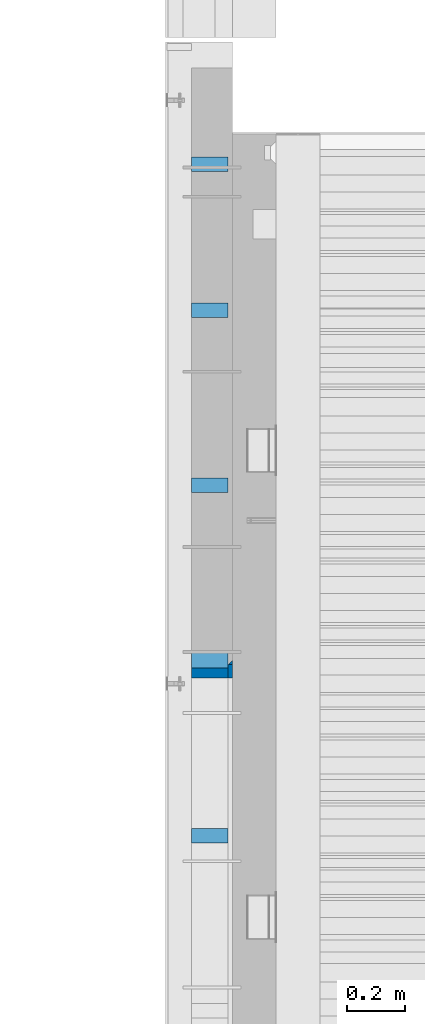
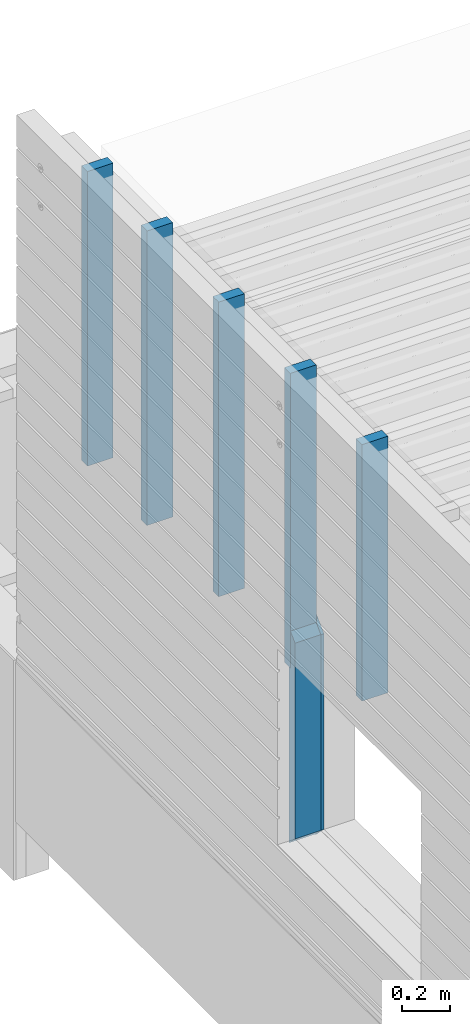
# One storey, part 3 of 153: 8 columns, 1 element without a shape of its own.
"""IFC2X3 building model written with IfcOpenShell, lengths in millimetres."""

from ifc_helpers import new_model, si_unit, frame, origin_with_axes, place, context, subcontext, project, spatial, faceted_brep, material, type_object, element, aggregate, save


model = new_model("IFC2X3")

# Units and contexts
model_context = context("Model", 3, precision=1e-05, world=origin_with_axes())
body_context = subcontext(model_context, "Body", "Model", "MODEL_VIEW")
ifc_project = project(units=[si_unit("LENGTHUNIT", "METRE", prefix="MILLI"), si_unit("AREAUNIT", "SQUARE_METRE"), si_unit("VOLUMEUNIT", "CUBIC_METRE"), si_unit("MASSUNIT", "GRAM", prefix="KILO"), si_unit("TIMEUNIT", "SECOND"), si_unit("PLANEANGLEUNIT", "RADIAN"), si_unit("SOLIDANGLEUNIT", "STERADIAN"), si_unit("THERMODYNAMICTEMPERATUREUNIT", "DEGREE_CELSIUS"), si_unit("LUMINOUSINTENSITYUNIT", "LUMEN")], contexts=[model_context])

# Site, building, storey
site_placement = place(None, origin_with_axes())
site = spatial("IfcSite", under=ifc_project, at=site_placement, CompositionType="ELEMENT")
building_placement = place(site_placement, origin_with_axes())
building = spatial("IfcBuilding", under=site, at=building_placement, CompositionType="ELEMENT")
storey_placement = place(building_placement, origin_with_axes())
storey = spatial("IfcBuildingStorey", under=building, at=storey_placement, Name="8", CompositionType="ELEMENT", Elevation=0.0)

# Assembly, columns
assembly_placement = place(storey_placement, origin_with_axes())
assembly = element("IfcElementAssembly", 1, at=assembly_placement, inside=storey, AssemblyPlace="NOTDEFINED", PredefinedType="REINFORCEMENT_UNIT")
ifc_material_1 = material(Name="CONCRETE/C25/30")
column_type_1 = type_object("IfcColumnType", PredefinedType="NOTDEFINED")
column_1_placement = place(assembly_placement, frame((7842.5, 18758.7493324854, 103895.0), z_axis=(0.0, -1.0, 0.0), x_axis=(0.0, 0.0, 1.0)))
column_1 = element("IfcColumn", 2, at=column_1_placement, type_object=column_type_1, material=ifc_material_1, context=body_context, shape_type="Brep", body=[
    faceted_brep([(1115.0, -7.5, 7.5), (1130.0, -7.5, -7.5), (1115.0, 7.5, 7.5), (0.0, -7.5, -7.5), (15.0000000000036, 7.5, 7.5), (15.0000000000036, -7.5, 7.5)], [[[0, 1, 2]], [[2, 1, 3, 4]], [[0, 2, 4, 5]], [[1, 0, 5, 3]], [[4, 3, 5]]]),
])
column_type_2 = type_object("IfcColumnType", PredefinedType="NOTDEFINED")
column_2_placement = place(assembly_placement, frame((7842.5, 18726.2493324854, 103910.0), z_axis=(0.0, -1.0, 0.0), x_axis=(0.0, 0.0, 1.0)))
column_2 = element("IfcColumn", 3, at=column_2_placement, type_object=column_type_2, material=ifc_material_1, context=body_context, shape_type="Brep", body=[
    faceted_brep([(1050.00000000001, 7.5, 25.0), (1050.0, -7.5, 25.0), (1100.0, -7.5, -25.0), (1100.0, 7.5, -25.0), (0.0, -7.5, -25.0), (0.0, 7.5, -25.0), (50.0000000000036, 7.5, 25.0), (50.0, -7.5, 25.0)], [[[0, 1, 2, 3]], [[3, 2, 4, 5]], [[0, 3, 5, 6]], [[1, 0, 6, 7]], [[2, 1, 7, 4]], [[6, 5, 4, 7]]]),
])
ifc_material_2 = material(Name="TIMBER")
column_type_3 = type_object("IfcColumnType", Name="50X125", PredefinedType="NOTDEFINED")
column_3_placement = place(assembly_placement, frame((7772.5, 18726.2493324854, 103910.0), z_axis=(0.0, -1.0, 0.0), x_axis=(0.0, 0.0, 1.0)))
column_3 = element("IfcColumn", 4, at=column_3_placement, type_object=column_type_3, material=ifc_material_2, ObjectType="50X125", context=body_context, shape_type="Brep", body=[
    faceted_brep([(1100.0, 62.5, -25.0), (1050.00000000001, 62.5, 25.0), (1050.00000000001, -62.5, 25.0), (1100.0, -62.5, -25.0), (0.0, -62.5, -25.0), (0.0, 62.5, -25.0), (49.9999999999818, 62.5, 25.0), (49.9999999999818, -62.5, 25.0)], [[[0, 1, 2, 3]], [[4, 5, 0, 3]], [[5, 6, 1, 0]], [[6, 7, 2, 1]], [[7, 4, 3, 2]], [[6, 5, 4, 7]]]),
])
ifc_material_3 = material(Name="TIMBER/T24")
column_type_4 = type_object("IfcColumnType", Name="PK50X125", PredefinedType="NOTDEFINED")
column_4_placement = place(assembly_placement, frame((7772.49680351058, 18165.0, 105004.0), z_axis=(1.0, 0.0, 0.0), x_axis=(0.0, 0.0, 1.0)))
column_4 = element("IfcColumn", 5, at=column_4_placement, type_object=column_type_4, material=ifc_material_3, ObjectType="PK50X125", context=body_context, shape_type="Brep", body=[
    faceted_brep([(0.0, 25.0, 62.5), (0.0, -25.0, 62.5), (1311.0, -25.0, 62.5), (1311.0, 25.0, 62.5), (0.0, -25.0, -62.5), (1311.0, -25.0, -62.5), (0.0, 25.0, -62.5), (1311.0, 25.0, -62.5)], [[[0, 1, 2, 3]], [[1, 4, 5, 2]], [[4, 6, 7, 5]], [[6, 0, 3, 7]], [[5, 7, 3, 2]], [[6, 4, 1, 0]]]),
])
column_5_placement = place(assembly_placement, frame((7772.49680351058, 18765.0, 104810.0), z_axis=(1.0, 0.0, 0.0), x_axis=(0.0, 0.0, 1.0)))
column_5 = element("IfcColumn", 6, at=column_5_placement, type_object=column_type_4, material=ifc_material_3, ObjectType="PK50X125", context=body_context, shape_type="Brep", body=[
    faceted_brep([(0.0, 25.0, 62.5), (0.0, -25.0, 62.5), (1505.0, -25.0, 62.5), (1505.0, 25.0, 62.5), (0.0, -25.0, -62.5), (1505.0, -25.0, -62.5), (0.0, 25.0, -62.5), (1505.0, 25.0, -62.5)], [[[0, 1, 2, 3]], [[1, 4, 5, 2]], [[4, 6, 7, 5]], [[6, 0, 3, 7]], [[5, 7, 3, 2]], [[6, 4, 1, 0]]]),
])
column_6_placement = place(assembly_placement, frame((7772.49680351058, 19365.0, 104809.99), z_axis=(1.0, 0.0, 0.0), x_axis=(0.0, 0.0, 1.0)))
column_6 = element("IfcColumn", 7, at=column_6_placement, type_object=column_type_4, material=ifc_material_3, ObjectType="PK50X125", context=body_context, shape_type="Brep", body=[
    faceted_brep([(0.0, 25.0, 62.5), (0.0, -25.0, 62.5), (1505.00999999999, -25.0, 62.5), (1505.00999999999, 25.0, 62.5), (0.0, -25.0, -62.5), (1505.00999999999, -25.0, -62.5), (0.0, 25.0, -62.5), (1505.00999999999, 25.0, -62.5)], [[[0, 1, 2, 3]], [[1, 4, 5, 2]], [[4, 6, 7, 5]], [[6, 0, 3, 7]], [[5, 7, 3, 2]], [[6, 4, 1, 0]]]),
])
column_7_placement = place(assembly_placement, frame((7772.49680351058, 19965.0, 104809.99), z_axis=(1.0, 0.0, 0.0), x_axis=(0.0, 0.0, 1.0)))
column_7 = element("IfcColumn", 8, at=column_7_placement, type_object=column_type_4, material=ifc_material_3, ObjectType="PK50X125", context=body_context, shape_type="Brep", body=[
    faceted_brep([(0.0, 25.0, 62.5), (0.0, -25.0, 62.5), (1505.00999999999, -25.0, 62.5), (1505.00999999999, 25.0, 62.5), (0.0, -25.0, -62.5), (1505.00999999999, -25.0, -62.5), (0.0, 25.0, -62.5), (1505.00999999999, 25.0, -62.5)], [[[0, 1, 2, 3]], [[1, 4, 5, 2]], [[4, 6, 7, 5]], [[6, 0, 3, 7]], [[5, 7, 3, 2]], [[6, 4, 1, 0]]]),
])
column_8_placement = place(assembly_placement, frame((7772.49680351058, 20465.0, 104810.0), z_axis=(1.0, 0.0, 0.0), x_axis=(0.0, 0.0, 1.0)))
column_8 = element("IfcColumn", 9, at=column_8_placement, type_object=column_type_4, material=ifc_material_3, ObjectType="PK50X125", context=body_context, shape_type="Brep", body=[
    faceted_brep([(0.0, 25.0, 62.5), (0.0, -25.0, 62.5), (1505.0, -25.0, 62.5), (1505.0, 25.0, 62.5), (0.0, -25.0, -62.5), (1505.0, -25.0, -62.5), (0.0, 25.0, -62.5), (1505.0, 25.0, -62.5)], [[[0, 1, 2, 3]], [[1, 4, 5, 2]], [[4, 6, 7, 5]], [[6, 0, 3, 7]], [[5, 7, 3, 2]], [[6, 4, 1, 0]]]),
])
aggregate(assembly, [column_1, column_2, column_3, column_4, column_5, column_6, column_7, column_8])

save(model, "model.ifc")
